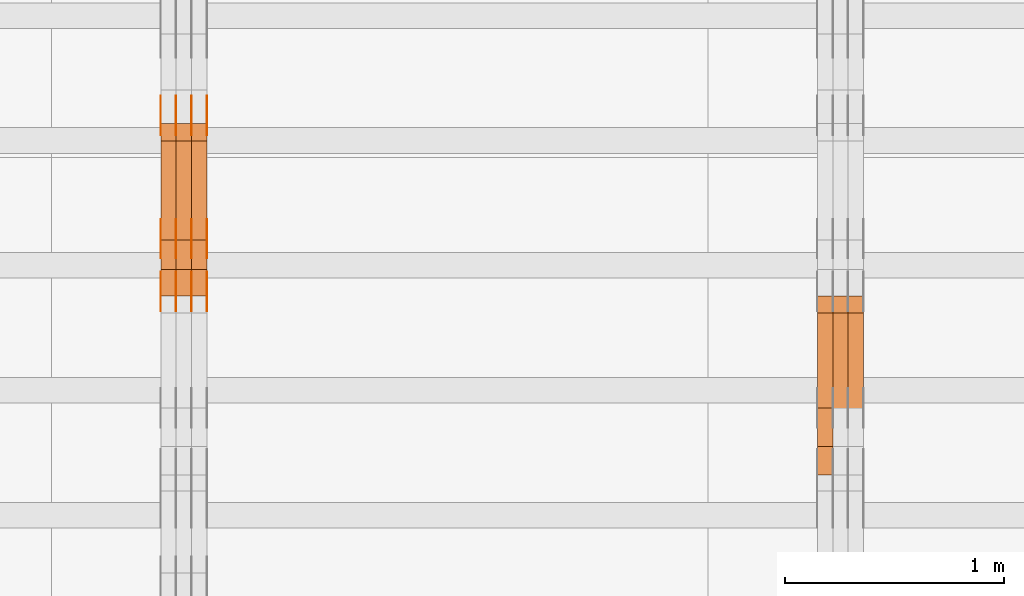
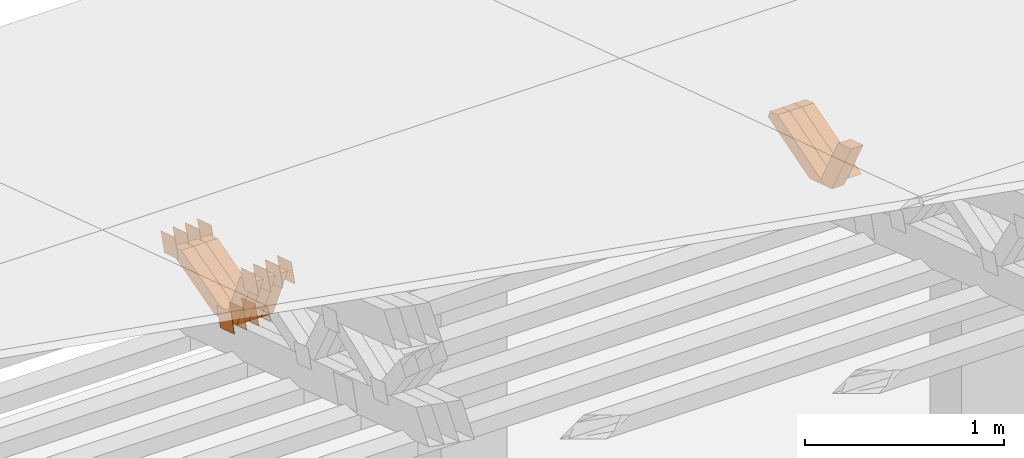
# One storey, part 358 of 385: 28 proxies.
"""IFC2X3 building model written with IfcOpenShell, lengths in millimetres."""

from ifc_helpers import new_model, entity, si_unit, converted_unit, derived_unit, direction, frame, origin, place, context, subcontext, project, spatial, polyline, outline, extrude, source, transform, mapped, material, type_object, type_shapes, element, save


model = new_model("IFC2X3")

# Units and contexts
model_context = context("Model", 3, precision=0.01, world=origin(), true_north=direction((6.12303176911189e-17, 1.0)))
body_context = subcontext(model_context, "Body", "Model", "MODEL_VIEW")
ifc_project = project(units=[si_unit("LENGTHUNIT", "METRE", prefix="MILLI"), si_unit("AREAUNIT", "SQUARE_METRE"), si_unit("VOLUMEUNIT", "CUBIC_METRE"), converted_unit("PLANEANGLEUNIT", "DEGREE", entity("IfcRatioMeasure", 0.0174532925199433), si_unit("PLANEANGLEUNIT", "RADIAN"), dimensions=[0, 0, 0, 0, 0, 0, 0]), si_unit("MASSUNIT", "GRAM", prefix="KILO"), derived_unit("MASSDENSITYUNIT", [(si_unit("MASSUNIT", "GRAM", prefix="KILO"), 1), (si_unit("LENGTHUNIT", "METRE"), -3)]), si_unit("TIMEUNIT", "SECOND"), si_unit("FREQUENCYUNIT", "HERTZ"), si_unit("THERMODYNAMICTEMPERATUREUNIT", "DEGREE_CELSIUS"), derived_unit("THERMALTRANSMITTANCEUNIT", [(si_unit("MASSUNIT", "GRAM", prefix="KILO"), 1), (si_unit("THERMODYNAMICTEMPERATUREUNIT", "KELVIN"), -1), (si_unit("TIMEUNIT", "SECOND"), -3)]), derived_unit("VOLUMETRICFLOWRATEUNIT", [(si_unit("LENGTHUNIT", "METRE"), 3), (si_unit("TIMEUNIT", "SECOND"), -1)]), si_unit("ELECTRICCURRENTUNIT", "AMPERE"), si_unit("ELECTRICVOLTAGEUNIT", "VOLT"), si_unit("POWERUNIT", "WATT"), si_unit("FORCEUNIT", "NEWTON", prefix="KILO"), si_unit("ILLUMINANCEUNIT", "LUX"), si_unit("LUMINOUSFLUXUNIT", "LUMEN"), si_unit("LUMINOUSINTENSITYUNIT", "CANDELA"), derived_unit("USERDEFINED", [(si_unit("MASSUNIT", "GRAM", prefix="KILO"), -1), (si_unit("LENGTHUNIT", "METRE"), -2), (si_unit("TIMEUNIT", "SECOND"), 3), (si_unit("LUMINOUSFLUXUNIT", "LUMEN"), 1)]), derived_unit("LINEARVELOCITYUNIT", [(si_unit("LENGTHUNIT", "METRE"), 1), (si_unit("TIMEUNIT", "SECOND"), -1)]), si_unit("PRESSUREUNIT", "PASCAL"), derived_unit("USERDEFINED", [(si_unit("LENGTHUNIT", "METRE"), -2), (si_unit("MASSUNIT", "GRAM", prefix="KILO"), 1), (si_unit("TIMEUNIT", "SECOND"), -2)])], contexts=[model_context])

# Site, building, storey
site_placement = place(None, origin())
site = spatial("IfcSite", under=ifc_project, at=site_placement, CompositionType="ELEMENT")
building_placement = place(site_placement, origin())
building = spatial("IfcBuilding", under=site, at=building_placement, CompositionType="ELEMENT")
storey_placement = place(building_placement, origin())
storey = spatial("IfcBuildingStorey", under=building, at=storey_placement, Name="Default", CompositionType="ELEMENT", Elevation=0.0)

# Proxies
ifc_material_1 = material(Name="IfcSurfaceStyle #528614")
building_element_proxy_type_1 = type_object("IfcBuildingElementProxyType", Name="T1-W41 528612", PredefinedType="NOTDEFINED", material=ifc_material_1)
shared_shape_1 = source(origin(), body_context, "Body", "SweptSolid", [
    extrude(outline(polyline([(-190.064783497519, -47.5001011048749), (182.590736871656, -47.5001011048749), (172.978793750747, 0.000111395300689243), (123.505951450908, 47.5000454072246), (-289.010698575792, 47.5000454072246), (-190.064783497519, -47.5001011048749)])), frame((182.590736871656, 47.5001973817447, 0.0), z_axis=(0.0, 0.0, 1.0), x_axis=(-1.0, 0.0, 0.0)), (0.0, 0.0, 1.0), 70.0),
])
type_shapes(building_element_proxy_type_1, [shared_shape_1])
proxy_1_placement = place(building_placement, frame((45245.0, 22512.5506969064, 1347.13648051689), z_axis=(-1.0, 0.0, 0.0), x_axis=(0.0, -0.472020158706979, 0.881587755004706)))
element("IfcBuildingElementProxy", 1, at=proxy_1_placement, inside=storey, type_object=building_element_proxy_type_1, material=ifc_material_1, Name="T1-W41", context=body_context, shape_type="MappedRepresentation", body=[
    mapped(shared_shape_1, transform((0.0, 0.0, 0.0), scale=1.0)),
])
ifc_material_2 = material(Name="IfcSurfaceStyle #528350")
building_element_proxy_type_2 = type_object("IfcBuildingElementProxyType", Name="T1-W23 528348", PredefinedType="NOTDEFINED", material=ifc_material_2)
shared_shape_2 = source(origin(), body_context, "Body", "SweptSolid", [
    extrude(outline(polyline([(-356.808656505462, -47.5000180192671), (144.726334557508, -47.5000180192671), (213.258834104997, -2.90494310381195e-05), (218.567145253444, 47.5000325439826), (-219.743657410487, 47.5000325439827), (-356.808656505462, -47.5000180192671)])), frame((218.567145253444, 47.5000325439826, 0.0), z_axis=(0.0, 0.0, 1.0), x_axis=(-1.0, 0.0, 0.0)), (0.0, 0.0, 1.0), 70.0),
])
type_shapes(building_element_proxy_type_2, [shared_shape_2])
proxy_2_placement = place(building_placement, frame((45385.0, 23128.2626953125, 1452.63940429688), z_axis=(-1.0, 0.0, 0.0), x_axis=(0.0, -0.957692700226705, -0.287792793399143)))
element("IfcBuildingElementProxy", 2, at=proxy_2_placement, inside=storey, type_object=building_element_proxy_type_2, material=ifc_material_2, Name="T1-W23", context=body_context, shape_type="MappedRepresentation", body=[
    mapped(shared_shape_2, transform((0.0, 0.0, 0.0), scale=1.0)),
])
ifc_material_3 = material(Name="IfcSurfaceStyle #528284")
building_element_proxy_type_3 = type_object("IfcBuildingElementProxyType", Name="T1-W23 528282", PredefinedType="NOTDEFINED", material=ifc_material_3)
shared_shape_3 = source(origin(), body_context, "Body", "SweptSolid", [
    extrude(outline(polyline([(-356.808656505462, -47.5000180192671), (144.726334557508, -47.5000180192671), (213.258834104997, -2.90494310381195e-05), (218.567145253444, 47.5000325439826), (-219.743657410487, 47.5000325439827), (-356.808656505462, -47.5000180192671)])), frame((218.567145253444, 47.5000325439826, 0.0), z_axis=(0.0, 0.0, 1.0), x_axis=(-1.0, 0.0, 0.0)), (0.0, 0.0, 1.0), 70.0),
])
type_shapes(building_element_proxy_type_3, [shared_shape_3])
proxy_3_placement = place(building_placement, frame((45315.0, 23128.2626953125, 1452.63940429688), z_axis=(-1.0, 0.0, 0.0), x_axis=(0.0, -0.957692700226705, -0.287792793399143)))
element("IfcBuildingElementProxy", 3, at=proxy_3_placement, inside=storey, type_object=building_element_proxy_type_3, material=ifc_material_3, Name="T1-W23", context=body_context, shape_type="MappedRepresentation", body=[
    mapped(shared_shape_3, transform((0.0, 0.0, 0.0), scale=1.0)),
])
ifc_material_4 = material(Name="IfcSurfaceStyle #528218")
building_element_proxy_type_4 = type_object("IfcBuildingElementProxyType", Name="T1-W23 528216", PredefinedType="NOTDEFINED", material=ifc_material_4)
shared_shape_4 = source(origin(), body_context, "Body", "SweptSolid", [
    extrude(outline(polyline([(-356.808656505462, -47.5000180192671), (144.726334557508, -47.5000180192671), (213.258834104997, -2.90494310381195e-05), (218.567145253444, 47.5000325439826), (-219.743657410487, 47.5000325439827), (-356.808656505462, -47.5000180192671)])), frame((218.567145253444, 47.5000325439826, 0.0), z_axis=(0.0, 0.0, 1.0), x_axis=(-1.0, 0.0, 0.0)), (0.0, 0.0, 1.0), 70.0),
])
type_shapes(building_element_proxy_type_4, [shared_shape_4])
proxy_4_placement = place(building_placement, frame((45245.0, 23128.2626953125, 1452.63940429688), z_axis=(-1.0, 0.0, 0.0), x_axis=(0.0, -0.957692700226705, -0.287792793399143)))
element("IfcBuildingElementProxy", 4, at=proxy_4_placement, inside=storey, type_object=building_element_proxy_type_4, material=ifc_material_4, Name="T1-W23", context=body_context, shape_type="MappedRepresentation", body=[
    mapped(shared_shape_4, transform((0.0, 0.0, 0.0), scale=1.0)),
])
ifc_material_5 = material(Name="IfcSurfaceStyle #506374")
building_element_proxy_type_5 = type_object("IfcBuildingElementProxyType", PredefinedType="NOTDEFINED", material=ifc_material_5)
shared_shape_5 = source(origin(), body_context, "Body", "SweptSolid", [
    extrude(outline(polyline([(-74.9998888504569, -59.9999264677525), (74.999884859074, -59.9999264677525), (74.9998699895559, 59.9999264677525), (-74.999865998173, 59.9999264677525), (-74.9998888504569, -59.9999264677525)])), frame((74.9999170714918, 60.0000016373507, 0.0), z_axis=(0.0, 0.0, 1.0), x_axis=(-1.0, 0.0, 0.0)), (0.0, 0.0, 1.0), 1.3),
])
type_shapes(building_element_proxy_type_5, [shared_shape_5])
proxy_5_placement = place(building_placement, frame((42386.3, 23182.5962361838, 1409.76695322432), z_axis=(-1.0, 0.0, 0.0), x_axis=(0.0, -0.951056516295154, 0.309016994374948)))
element("IfcBuildingElementProxy", 5, at=proxy_5_placement, inside=storey, type_object=building_element_proxy_type_5, material=ifc_material_5, context=body_context, shape_type="MappedRepresentation", body=[
    mapped(shared_shape_5, transform((0.0, 0.0, 0.0), scale=1.0)),
])
ifc_material_6 = material(Name="IfcSurfaceStyle #506317")
building_element_proxy_type_6 = type_object("IfcBuildingElementProxyType", PredefinedType="NOTDEFINED", material=ifc_material_6)
shared_shape_6 = source(origin(), body_context, "Body", "SweptSolid", [
    extrude(outline(polyline([(-74.9998888504569, -59.9999264677525), (74.999884859074, -59.9999264677525), (74.9998699895559, 59.9999264677525), (-74.999865998173, 59.9999264677525), (-74.9998888504569, -59.9999264677525)])), frame((74.9999170714918, 60.0000016373507, 0.0), z_axis=(0.0, 0.0, 1.0), x_axis=(-1.0, 0.0, 0.0)), (0.0, 0.0, 1.0), 1.3),
])
type_shapes(building_element_proxy_type_6, [shared_shape_6])
proxy_6_placement = place(building_placement, frame((42315.0, 23182.5962361838, 1409.76695322432), z_axis=(-1.0, 0.0, 0.0), x_axis=(0.0, -0.951056516295154, 0.309016994374948)))
element("IfcBuildingElementProxy", 6, at=proxy_6_placement, inside=storey, type_object=building_element_proxy_type_6, material=ifc_material_6, context=body_context, shape_type="MappedRepresentation", body=[
    mapped(shared_shape_6, transform((0.0, 0.0, 0.0), scale=1.0)),
])
ifc_material_7 = material(Name="IfcSurfaceStyle #506260")
building_element_proxy_type_7 = type_object("IfcBuildingElementProxyType", PredefinedType="NOTDEFINED", material=ifc_material_7)
shared_shape_7 = source(origin(), body_context, "Body", "SweptSolid", [
    extrude(outline(polyline([(-74.9998888504569, -59.9999264677525), (74.999884859074, -59.9999264677525), (74.9998699895559, 59.9999264677525), (-74.999865998173, 59.9999264677525), (-74.9998888504569, -59.9999264677525)])), frame((74.9999170714918, 60.0000016373507, 0.0), z_axis=(0.0, 0.0, 1.0), x_axis=(-1.0, 0.0, 0.0)), (0.0, 0.0, 1.0), 1.3),
])
type_shapes(building_element_proxy_type_7, [shared_shape_7])
proxy_7_placement = place(building_placement, frame((42316.3, 23182.5962361838, 1409.76695322432), z_axis=(-1.0, 0.0, 0.0), x_axis=(0.0, -0.951056516295154, 0.309016994374948)))
element("IfcBuildingElementProxy", 7, at=proxy_7_placement, inside=storey, type_object=building_element_proxy_type_7, material=ifc_material_7, context=body_context, shape_type="MappedRepresentation", body=[
    mapped(shared_shape_7, transform((0.0, 0.0, 0.0), scale=1.0)),
])
ifc_material_8 = material(Name="IfcSurfaceStyle #506203")
building_element_proxy_type_8 = type_object("IfcBuildingElementProxyType", PredefinedType="NOTDEFINED", material=ifc_material_8)
shared_shape_8 = source(origin(), body_context, "Body", "SweptSolid", [
    extrude(outline(polyline([(-74.9998888504569, -59.9999264677525), (74.999884859074, -59.9999264677525), (74.9998699895559, 59.9999264677525), (-74.999865998173, 59.9999264677525), (-74.9998888504569, -59.9999264677525)])), frame((74.9999170714918, 60.0000016373507, 0.0), z_axis=(0.0, 0.0, 1.0), x_axis=(-1.0, 0.0, 0.0)), (0.0, 0.0, 1.0), 1.29999999999999),
])
type_shapes(building_element_proxy_type_8, [shared_shape_8])
proxy_8_placement = place(building_placement, frame((42245.0, 23182.5962361838, 1409.76695322432), z_axis=(-1.0, 0.0, 0.0), x_axis=(0.0, -0.951056516295154, 0.309016994374948)))
element("IfcBuildingElementProxy", 8, at=proxy_8_placement, inside=storey, type_object=building_element_proxy_type_8, material=ifc_material_8, context=body_context, shape_type="MappedRepresentation", body=[
    mapped(shared_shape_8, transform((0.0, 0.0, 0.0), scale=1.0)),
])
ifc_material_9 = material(Name="IfcSurfaceStyle #506146")
building_element_proxy_type_9 = type_object("IfcBuildingElementProxyType", PredefinedType="NOTDEFINED", material=ifc_material_9)
shared_shape_9 = source(origin(), body_context, "Body", "SweptSolid", [
    extrude(outline(polyline([(-74.9998888504569, -59.9999264677525), (74.999884859074, -59.9999264677525), (74.9998699895559, 59.9999264677525), (-74.999865998173, 59.9999264677525), (-74.9998888504569, -59.9999264677525)])), frame((74.9999170714918, 60.0000016373507, 0.0), z_axis=(0.0, 0.0, 1.0), x_axis=(-1.0, 0.0, 0.0)), (0.0, 0.0, 1.0), 1.29999999999999),
])
type_shapes(building_element_proxy_type_9, [shared_shape_9])
proxy_9_placement = place(building_placement, frame((42246.3, 23182.5962361838, 1409.76695322432), z_axis=(-1.0, 0.0, 0.0), x_axis=(0.0, -0.951056516295154, 0.309016994374948)))
element("IfcBuildingElementProxy", 9, at=proxy_9_placement, inside=storey, type_object=building_element_proxy_type_9, material=ifc_material_9, context=body_context, shape_type="MappedRepresentation", body=[
    mapped(shared_shape_9, transform((0.0, 0.0, 0.0), scale=1.0)),
])
ifc_material_10 = material(Name="IfcSurfaceStyle #506089")
building_element_proxy_type_10 = type_object("IfcBuildingElementProxyType", PredefinedType="NOTDEFINED", material=ifc_material_10)
shared_shape_10 = source(origin(), body_context, "Body", "SweptSolid", [
    extrude(outline(polyline([(-74.9998888504569, -59.9999264677525), (74.999884859074, -59.9999264677525), (74.9998699895559, 59.9999264677525), (-74.999865998173, 59.9999264677525), (-74.9998888504569, -59.9999264677525)])), frame((74.9999170714918, 60.0000016373507, 0.0), z_axis=(0.0, 0.0, 1.0), x_axis=(-1.0, 0.0, 0.0)), (0.0, 0.0, 1.0), 1.29999999999999),
])
type_shapes(building_element_proxy_type_10, [shared_shape_10])
proxy_10_placement = place(building_placement, frame((42175.0, 23182.5962361838, 1409.76695322432), z_axis=(-1.0, 0.0, 0.0), x_axis=(0.0, -0.951056516295154, 0.309016994374948)))
element("IfcBuildingElementProxy", 10, at=proxy_10_placement, inside=storey, type_object=building_element_proxy_type_10, material=ifc_material_10, context=body_context, shape_type="MappedRepresentation", body=[
    mapped(shared_shape_10, transform((0.0, 0.0, 0.0), scale=1.0)),
])
ifc_material_11 = material(Name="IfcSurfaceStyle #506032")
building_element_proxy_type_11 = type_object("IfcBuildingElementProxyType", PredefinedType="NOTDEFINED", material=ifc_material_11)
shared_shape_11 = source(origin(), body_context, "Body", "SweptSolid", [
    extrude(outline(polyline([(-75.000111611545, -60.0000599592451), (75.0000887592491, -60.0000599592451), (75.000111611545, 60.0000599592451), (-75.0000887592492, 60.0000599592451), (-75.000111611545, -60.0000599592451)])), frame((75.000111611545, 60.0000599592451, 0.0), z_axis=(0.0, 0.0, 1.0), x_axis=(-1.0, 0.0, 0.0)), (0.0, 0.0, 1.0), 1.3),
])
type_shapes(building_element_proxy_type_11, [shared_shape_11])
proxy_11_placement = place(building_placement, frame((42386.3, 23422.738257852, 1031.33757447264), z_axis=(-1.0, 0.0, 0.0), x_axis=(0.0, -0.951056516295124, 0.309016994375039)))
element("IfcBuildingElementProxy", 11, at=proxy_11_placement, inside=storey, type_object=building_element_proxy_type_11, material=ifc_material_11, context=body_context, shape_type="MappedRepresentation", body=[
    mapped(shared_shape_11, transform((0.0, 0.0, 0.0), scale=1.0)),
])
ifc_material_12 = material(Name="IfcSurfaceStyle #505975")
building_element_proxy_type_12 = type_object("IfcBuildingElementProxyType", PredefinedType="NOTDEFINED", material=ifc_material_12)
shared_shape_12 = source(origin(), body_context, "Body", "SweptSolid", [
    extrude(outline(polyline([(-75.000111611545, -60.0000599592451), (75.0000887592491, -60.0000599592451), (75.000111611545, 60.0000599592451), (-75.0000887592492, 60.0000599592451), (-75.000111611545, -60.0000599592451)])), frame((75.000111611545, 60.0000599592451, 0.0), z_axis=(0.0, 0.0, 1.0), x_axis=(-1.0, 0.0, 0.0)), (0.0, 0.0, 1.0), 1.3),
])
type_shapes(building_element_proxy_type_12, [shared_shape_12])
proxy_12_placement = place(building_placement, frame((42315.0, 23422.738257852, 1031.33757447264), z_axis=(-1.0, 0.0, 0.0), x_axis=(0.0, -0.951056516295124, 0.309016994375039)))
element("IfcBuildingElementProxy", 12, at=proxy_12_placement, inside=storey, type_object=building_element_proxy_type_12, material=ifc_material_12, context=body_context, shape_type="MappedRepresentation", body=[
    mapped(shared_shape_12, transform((0.0, 0.0, 0.0), scale=1.0)),
])
ifc_material_13 = material(Name="IfcSurfaceStyle #505918")
building_element_proxy_type_13 = type_object("IfcBuildingElementProxyType", PredefinedType="NOTDEFINED", material=ifc_material_13)
shared_shape_13 = source(origin(), body_context, "Body", "SweptSolid", [
    extrude(outline(polyline([(-75.000111611545, -60.0000599592451), (75.0000887592491, -60.0000599592451), (75.000111611545, 60.0000599592451), (-75.0000887592492, 60.0000599592451), (-75.000111611545, -60.0000599592451)])), frame((75.000111611545, 60.0000599592451, 0.0), z_axis=(0.0, 0.0, 1.0), x_axis=(-1.0, 0.0, 0.0)), (0.0, 0.0, 1.0), 1.3),
])
type_shapes(building_element_proxy_type_13, [shared_shape_13])
proxy_13_placement = place(building_placement, frame((42316.3, 23422.738257852, 1031.33757447264), z_axis=(-1.0, 0.0, 0.0), x_axis=(0.0, -0.951056516295124, 0.309016994375039)))
element("IfcBuildingElementProxy", 13, at=proxy_13_placement, inside=storey, type_object=building_element_proxy_type_13, material=ifc_material_13, context=body_context, shape_type="MappedRepresentation", body=[
    mapped(shared_shape_13, transform((0.0, 0.0, 0.0), scale=1.0)),
])
ifc_material_14 = material(Name="IfcSurfaceStyle #505861")
building_element_proxy_type_14 = type_object("IfcBuildingElementProxyType", PredefinedType="NOTDEFINED", material=ifc_material_14)
shared_shape_14 = source(origin(), body_context, "Body", "SweptSolid", [
    extrude(outline(polyline([(-75.000111611545, -60.0000599592451), (75.0000887592491, -60.0000599592451), (75.000111611545, 60.0000599592451), (-75.0000887592492, 60.0000599592451), (-75.000111611545, -60.0000599592451)])), frame((75.000111611545, 60.0000599592451, 0.0), z_axis=(0.0, 0.0, 1.0), x_axis=(-1.0, 0.0, 0.0)), (0.0, 0.0, 1.0), 1.29999999999999),
])
type_shapes(building_element_proxy_type_14, [shared_shape_14])
proxy_14_placement = place(building_placement, frame((42245.0, 23422.738257852, 1031.33757447264), z_axis=(-1.0, 0.0, 0.0), x_axis=(0.0, -0.951056516295124, 0.309016994375039)))
element("IfcBuildingElementProxy", 14, at=proxy_14_placement, inside=storey, type_object=building_element_proxy_type_14, material=ifc_material_14, context=body_context, shape_type="MappedRepresentation", body=[
    mapped(shared_shape_14, transform((0.0, 0.0, 0.0), scale=1.0)),
])
ifc_material_15 = material(Name="IfcSurfaceStyle #505804")
building_element_proxy_type_15 = type_object("IfcBuildingElementProxyType", PredefinedType="NOTDEFINED", material=ifc_material_15)
shared_shape_15 = source(origin(), body_context, "Body", "SweptSolid", [
    extrude(outline(polyline([(-75.000111611545, -60.0000599592451), (75.0000887592491, -60.0000599592451), (75.000111611545, 60.0000599592451), (-75.0000887592492, 60.0000599592451), (-75.000111611545, -60.0000599592451)])), frame((75.000111611545, 60.0000599592451, 0.0), z_axis=(0.0, 0.0, 1.0), x_axis=(-1.0, 0.0, 0.0)), (0.0, 0.0, 1.0), 1.29999999999999),
])
type_shapes(building_element_proxy_type_15, [shared_shape_15])
proxy_15_placement = place(building_placement, frame((42246.3, 23422.738257852, 1031.33757447264), z_axis=(-1.0, 0.0, 0.0), x_axis=(0.0, -0.951056516295124, 0.309016994375039)))
element("IfcBuildingElementProxy", 15, at=proxy_15_placement, inside=storey, type_object=building_element_proxy_type_15, material=ifc_material_15, context=body_context, shape_type="MappedRepresentation", body=[
    mapped(shared_shape_15, transform((0.0, 0.0, 0.0), scale=1.0)),
])
ifc_material_16 = material(Name="IfcSurfaceStyle #505747")
building_element_proxy_type_16 = type_object("IfcBuildingElementProxyType", PredefinedType="NOTDEFINED", material=ifc_material_16)
shared_shape_16 = source(origin(), body_context, "Body", "SweptSolid", [
    extrude(outline(polyline([(-75.000111611545, -60.0000599592451), (75.0000887592491, -60.0000599592451), (75.000111611545, 60.0000599592451), (-75.0000887592492, 60.0000599592451), (-75.000111611545, -60.0000599592451)])), frame((75.000111611545, 60.0000599592451, 0.0), z_axis=(0.0, 0.0, 1.0), x_axis=(-1.0, 0.0, 0.0)), (0.0, 0.0, 1.0), 1.29999999999999),
])
type_shapes(building_element_proxy_type_16, [shared_shape_16])
proxy_16_placement = place(building_placement, frame((42175.0, 23422.738257852, 1031.33757447264), z_axis=(-1.0, 0.0, 0.0), x_axis=(0.0, -0.951056516295124, 0.309016994375039)))
element("IfcBuildingElementProxy", 16, at=proxy_16_placement, inside=storey, type_object=building_element_proxy_type_16, material=ifc_material_16, context=body_context, shape_type="MappedRepresentation", body=[
    mapped(shared_shape_16, transform((0.0, 0.0, 0.0), scale=1.0)),
])
ifc_material_17 = material(Name="IfcSurfaceStyle #505348")
building_element_proxy_type_17 = type_object("IfcBuildingElementProxyType", PredefinedType="NOTDEFINED", material=ifc_material_17)
shared_shape_17 = source(origin(), body_context, "Body", "SweptSolid", [
    extrude(outline(polyline([(-74.9999766548731, -60.0000019113547), (75.000223715922, -60.0000019113547), (74.9997444633404, 60.0000019113548), (-74.9999915243893, 60.0000019113547), (-74.9999766548731, -60.0000019113547)])), frame((75.0002237159219, 60.0000770809529, 0.0), z_axis=(0.0, 0.0, 1.0), x_axis=(-1.0, 0.0, 0.0)), (0.0, 0.0, 1.0), 1.3),
])
type_shapes(building_element_proxy_type_17, [shared_shape_17])
proxy_17_placement = place(building_placement, frame((42386.3, 23985.88473314, 1148.76266928562), z_axis=(-1.0, 0.0, 0.0), x_axis=(0.0, -0.951056516295154, 0.309016994374948)))
element("IfcBuildingElementProxy", 17, at=proxy_17_placement, inside=storey, type_object=building_element_proxy_type_17, material=ifc_material_17, context=body_context, shape_type="MappedRepresentation", body=[
    mapped(shared_shape_17, transform((0.0, 0.0, 0.0), scale=1.0)),
])
ifc_material_18 = material(Name="IfcSurfaceStyle #505291")
building_element_proxy_type_18 = type_object("IfcBuildingElementProxyType", PredefinedType="NOTDEFINED", material=ifc_material_18)
shared_shape_18 = source(origin(), body_context, "Body", "SweptSolid", [
    extrude(outline(polyline([(-74.9999766548731, -60.0000019113547), (75.000223715922, -60.0000019113547), (74.9997444633404, 60.0000019113548), (-74.9999915243893, 60.0000019113547), (-74.9999766548731, -60.0000019113547)])), frame((75.0002237159219, 60.0000770809529, 0.0), z_axis=(0.0, 0.0, 1.0), x_axis=(-1.0, 0.0, 0.0)), (0.0, 0.0, 1.0), 1.3),
])
type_shapes(building_element_proxy_type_18, [shared_shape_18])
proxy_18_placement = place(building_placement, frame((42315.0, 23985.88473314, 1148.76266928562), z_axis=(-1.0, 0.0, 0.0), x_axis=(0.0, -0.951056516295154, 0.309016994374948)))
element("IfcBuildingElementProxy", 18, at=proxy_18_placement, inside=storey, type_object=building_element_proxy_type_18, material=ifc_material_18, context=body_context, shape_type="MappedRepresentation", body=[
    mapped(shared_shape_18, transform((0.0, 0.0, 0.0), scale=1.0)),
])
ifc_material_19 = material(Name="IfcSurfaceStyle #505234")
building_element_proxy_type_19 = type_object("IfcBuildingElementProxyType", PredefinedType="NOTDEFINED", material=ifc_material_19)
shared_shape_19 = source(origin(), body_context, "Body", "SweptSolid", [
    extrude(outline(polyline([(-74.9999766548731, -60.0000019113547), (75.000223715922, -60.0000019113547), (74.9997444633404, 60.0000019113548), (-74.9999915243893, 60.0000019113547), (-74.9999766548731, -60.0000019113547)])), frame((75.0002237159219, 60.0000770809529, 0.0), z_axis=(0.0, 0.0, 1.0), x_axis=(-1.0, 0.0, 0.0)), (0.0, 0.0, 1.0), 1.3),
])
type_shapes(building_element_proxy_type_19, [shared_shape_19])
proxy_19_placement = place(building_placement, frame((42316.3, 23985.88473314, 1148.76266928562), z_axis=(-1.0, 0.0, 0.0), x_axis=(0.0, -0.951056516295154, 0.309016994374948)))
element("IfcBuildingElementProxy", 19, at=proxy_19_placement, inside=storey, type_object=building_element_proxy_type_19, material=ifc_material_19, context=body_context, shape_type="MappedRepresentation", body=[
    mapped(shared_shape_19, transform((0.0, 0.0, 0.0), scale=1.0)),
])
ifc_material_20 = material(Name="IfcSurfaceStyle #505177")
building_element_proxy_type_20 = type_object("IfcBuildingElementProxyType", PredefinedType="NOTDEFINED", material=ifc_material_20)
shared_shape_20 = source(origin(), body_context, "Body", "SweptSolid", [
    extrude(outline(polyline([(-74.9999766548731, -60.0000019113547), (75.000223715922, -60.0000019113547), (74.9997444633404, 60.0000019113548), (-74.9999915243893, 60.0000019113547), (-74.9999766548731, -60.0000019113547)])), frame((75.0002237159219, 60.0000770809529, 0.0), z_axis=(0.0, 0.0, 1.0), x_axis=(-1.0, 0.0, 0.0)), (0.0, 0.0, 1.0), 1.29999999999999),
])
type_shapes(building_element_proxy_type_20, [shared_shape_20])
proxy_20_placement = place(building_placement, frame((42245.0, 23985.88473314, 1148.76266928562), z_axis=(-1.0, 0.0, 0.0), x_axis=(0.0, -0.951056516295154, 0.309016994374948)))
element("IfcBuildingElementProxy", 20, at=proxy_20_placement, inside=storey, type_object=building_element_proxy_type_20, material=ifc_material_20, context=body_context, shape_type="MappedRepresentation", body=[
    mapped(shared_shape_20, transform((0.0, 0.0, 0.0), scale=1.0)),
])
ifc_material_21 = material(Name="IfcSurfaceStyle #505120")
building_element_proxy_type_21 = type_object("IfcBuildingElementProxyType", PredefinedType="NOTDEFINED", material=ifc_material_21)
shared_shape_21 = source(origin(), body_context, "Body", "SweptSolid", [
    extrude(outline(polyline([(-74.9999766548731, -60.0000019113547), (75.000223715922, -60.0000019113547), (74.9997444633404, 60.0000019113548), (-74.9999915243893, 60.0000019113547), (-74.9999766548731, -60.0000019113547)])), frame((75.0002237159219, 60.0000770809529, 0.0), z_axis=(0.0, 0.0, 1.0), x_axis=(-1.0, 0.0, 0.0)), (0.0, 0.0, 1.0), 1.29999999999999),
])
type_shapes(building_element_proxy_type_21, [shared_shape_21])
proxy_21_placement = place(building_placement, frame((42246.3, 23985.88473314, 1148.76266928562), z_axis=(-1.0, 0.0, 0.0), x_axis=(0.0, -0.951056516295154, 0.309016994374948)))
element("IfcBuildingElementProxy", 21, at=proxy_21_placement, inside=storey, type_object=building_element_proxy_type_21, material=ifc_material_21, context=body_context, shape_type="MappedRepresentation", body=[
    mapped(shared_shape_21, transform((0.0, 0.0, 0.0), scale=1.0)),
])
ifc_material_22 = material(Name="IfcSurfaceStyle #505063")
building_element_proxy_type_22 = type_object("IfcBuildingElementProxyType", PredefinedType="NOTDEFINED", material=ifc_material_22)
shared_shape_22 = source(origin(), body_context, "Body", "SweptSolid", [
    extrude(outline(polyline([(-74.9999766548731, -60.0000019113547), (75.000223715922, -60.0000019113547), (74.9997444633404, 60.0000019113548), (-74.9999915243893, 60.0000019113547), (-74.9999766548731, -60.0000019113547)])), frame((75.0002237159219, 60.0000770809529, 0.0), z_axis=(0.0, 0.0, 1.0), x_axis=(-1.0, 0.0, 0.0)), (0.0, 0.0, 1.0), 1.29999999999999),
])
type_shapes(building_element_proxy_type_22, [shared_shape_22])
proxy_22_placement = place(building_placement, frame((42175.0, 23985.88473314, 1148.76266928562), z_axis=(-1.0, 0.0, 0.0), x_axis=(0.0, -0.951056516295154, 0.309016994374948)))
element("IfcBuildingElementProxy", 22, at=proxy_22_placement, inside=storey, type_object=building_element_proxy_type_22, material=ifc_material_22, context=body_context, shape_type="MappedRepresentation", body=[
    mapped(shared_shape_22, transform((0.0, 0.0, 0.0), scale=1.0)),
])
ifc_material_23 = material(Name="IfcSurfaceStyle #493522")
building_element_proxy_type_23 = type_object("IfcBuildingElementProxyType", Name="T1-W48 493520", PredefinedType="NOTDEFINED", material=ifc_material_23)
shared_shape_23 = source(origin(), body_context, "Body", "SweptSolid", [
    extrude(outline(polyline([(-179.014659681673, -47.5001725722734), (164.970934255612, -47.5001725722734), (158.689466064455, -0.000154807462590734), (117.249257288395, 47.5002499760047), (-261.894997926789, 47.5002499760047), (-179.014659681673, -47.5001725722734)])), frame((164.970934255612, 47.5002499760047, 0.0), z_axis=(0.0, 0.0, 1.0), x_axis=(-1.0, 0.0, 0.0)), (0.0, 0.0, 1.0), 70.0),
])
type_shapes(building_element_proxy_type_23, [shared_shape_23])
proxy_23_placement = place(building_placement, frame((42385.0, 23276.999081075, 1103.96808602322), z_axis=(-1.0, 0.0, 0.0), x_axis=(0.0, -0.392372359952232, 0.919806463961586)))
element("IfcBuildingElementProxy", 23, at=proxy_23_placement, inside=storey, type_object=building_element_proxy_type_23, material=ifc_material_23, Name="T1-W48", context=body_context, shape_type="MappedRepresentation", body=[
    mapped(shared_shape_23, transform((0.0, 0.0, 0.0), scale=1.0)),
])
ifc_material_24 = material(Name="IfcSurfaceStyle #493456")
building_element_proxy_type_24 = type_object("IfcBuildingElementProxyType", Name="T1-W48 493454", PredefinedType="NOTDEFINED", material=ifc_material_24)
shared_shape_24 = source(origin(), body_context, "Body", "SweptSolid", [
    extrude(outline(polyline([(-179.014659681673, -47.5001725722734), (164.970934255612, -47.5001725722734), (158.689466064455, -0.000154807462590734), (117.249257288395, 47.5002499760047), (-261.894997926789, 47.5002499760047), (-179.014659681673, -47.5001725722734)])), frame((164.970934255612, 47.5002499760047, 0.0), z_axis=(0.0, 0.0, 1.0), x_axis=(-1.0, 0.0, 0.0)), (0.0, 0.0, 1.0), 70.0),
])
type_shapes(building_element_proxy_type_24, [shared_shape_24])
proxy_24_placement = place(building_placement, frame((42315.0, 23276.999081075, 1103.96808602322), z_axis=(-1.0, 0.0, 0.0), x_axis=(0.0, -0.392372359952232, 0.919806463961586)))
element("IfcBuildingElementProxy", 24, at=proxy_24_placement, inside=storey, type_object=building_element_proxy_type_24, material=ifc_material_24, Name="T1-W48", context=body_context, shape_type="MappedRepresentation", body=[
    mapped(shared_shape_24, transform((0.0, 0.0, 0.0), scale=1.0)),
])
ifc_material_25 = material(Name="IfcSurfaceStyle #493390")
building_element_proxy_type_25 = type_object("IfcBuildingElementProxyType", Name="T1-W48 493388", PredefinedType="NOTDEFINED", material=ifc_material_25)
shared_shape_25 = source(origin(), body_context, "Body", "SweptSolid", [
    extrude(outline(polyline([(-179.014659681673, -47.5001725722734), (164.970934255612, -47.5001725722734), (158.689466064455, -0.000154807462590734), (117.249257288395, 47.5002499760047), (-261.894997926789, 47.5002499760047), (-179.014659681673, -47.5001725722734)])), frame((164.970934255612, 47.5002499760047, 0.0), z_axis=(0.0, 0.0, 1.0), x_axis=(-1.0, 0.0, 0.0)), (0.0, 0.0, 1.0), 70.0),
])
type_shapes(building_element_proxy_type_25, [shared_shape_25])
proxy_25_placement = place(building_placement, frame((42245.0, 23276.999081075, 1103.96808602322), z_axis=(-1.0, 0.0, 0.0), x_axis=(0.0, -0.392372359952232, 0.919806463961586)))
element("IfcBuildingElementProxy", 25, at=proxy_25_placement, inside=storey, type_object=building_element_proxy_type_25, material=ifc_material_25, Name="T1-W48", context=body_context, shape_type="MappedRepresentation", body=[
    mapped(shared_shape_25, transform((0.0, 0.0, 0.0), scale=1.0)),
])
ifc_material_26 = material(Name="IfcSurfaceStyle #493126")
building_element_proxy_type_26 = type_object("IfcBuildingElementProxyType", Name="T1-W16 493124", PredefinedType="NOTDEFINED", material=ifc_material_26)
shared_shape_26 = source(origin(), body_context, "Body", "SweptSolid", [
    extrude(outline(polyline([(-370.757125176074, -47.4999438400901), (145.934648032773, -47.4999438400902), (217.511780472151, -4.11857860007858e-05), (234.91308660316, 47.4999644329832), (-227.602389932009, 47.4999644329832), (-370.757125176074, -47.4999438400901)])), frame((234.913162148205, 47.5000075544853, 0.0), z_axis=(0.0, 0.0, 1.0), x_axis=(-1.0, 0.0, 0.0)), (0.0, 0.0, 1.0), 70.0),
])
type_shapes(building_element_proxy_type_26, [shared_shape_26])
proxy_26_placement = place(building_placement, frame((42385.0, 23927.1704945031, 1199.43003244777), z_axis=(-1.0, 0.0, 0.0), x_axis=(0.0, -0.963308155550006, -0.268397834288666)))
element("IfcBuildingElementProxy", 26, at=proxy_26_placement, inside=storey, type_object=building_element_proxy_type_26, material=ifc_material_26, Name="T1-W16", context=body_context, shape_type="MappedRepresentation", body=[
    mapped(shared_shape_26, transform((0.0, 0.0, 0.0), scale=1.0)),
])
ifc_material_27 = material(Name="IfcSurfaceStyle #493060")
building_element_proxy_type_27 = type_object("IfcBuildingElementProxyType", Name="T1-W16 493058", PredefinedType="NOTDEFINED", material=ifc_material_27)
shared_shape_27 = source(origin(), body_context, "Body", "SweptSolid", [
    extrude(outline(polyline([(-370.757125176074, -47.4999438400901), (145.934648032773, -47.4999438400902), (217.511780472151, -4.11857860007858e-05), (234.91308660316, 47.4999644329832), (-227.602389932009, 47.4999644329832), (-370.757125176074, -47.4999438400901)])), frame((234.913162148205, 47.5000075544853, 0.0), z_axis=(0.0, 0.0, 1.0), x_axis=(-1.0, 0.0, 0.0)), (0.0, 0.0, 1.0), 70.0),
])
type_shapes(building_element_proxy_type_27, [shared_shape_27])
proxy_27_placement = place(building_placement, frame((42315.0, 23927.1704945031, 1199.43003244777), z_axis=(-1.0, 0.0, 0.0), x_axis=(0.0, -0.963308155550006, -0.268397834288666)))
element("IfcBuildingElementProxy", 27, at=proxy_27_placement, inside=storey, type_object=building_element_proxy_type_27, material=ifc_material_27, Name="T1-W16", context=body_context, shape_type="MappedRepresentation", body=[
    mapped(shared_shape_27, transform((0.0, 0.0, 0.0), scale=1.0)),
])
ifc_material_28 = material(Name="IfcSurfaceStyle #492994")
building_element_proxy_type_28 = type_object("IfcBuildingElementProxyType", Name="T1-W16 492992", PredefinedType="NOTDEFINED", material=ifc_material_28)
shared_shape_28 = source(origin(), body_context, "Body", "SweptSolid", [
    extrude(outline(polyline([(-370.757125176074, -47.4999438400901), (145.934648032773, -47.4999438400902), (217.511780472151, -4.11857860007858e-05), (234.91308660316, 47.4999644329832), (-227.602389932009, 47.4999644329832), (-370.757125176074, -47.4999438400901)])), frame((234.913162148205, 47.5000075544853, 0.0), z_axis=(0.0, 0.0, 1.0), x_axis=(-1.0, 0.0, 0.0)), (0.0, 0.0, 1.0), 70.0),
])
type_shapes(building_element_proxy_type_28, [shared_shape_28])
proxy_28_placement = place(building_placement, frame((42245.0, 23927.1704945031, 1199.43003244777), z_axis=(-1.0, 0.0, 0.0), x_axis=(0.0, -0.963308155550006, -0.268397834288666)))
element("IfcBuildingElementProxy", 28, at=proxy_28_placement, inside=storey, type_object=building_element_proxy_type_28, material=ifc_material_28, Name="T1-W16", context=body_context, shape_type="MappedRepresentation", body=[
    mapped(shared_shape_28, transform((0.0, 0.0, 0.0), scale=1.0)),
])

save(model, "model.ifc")
